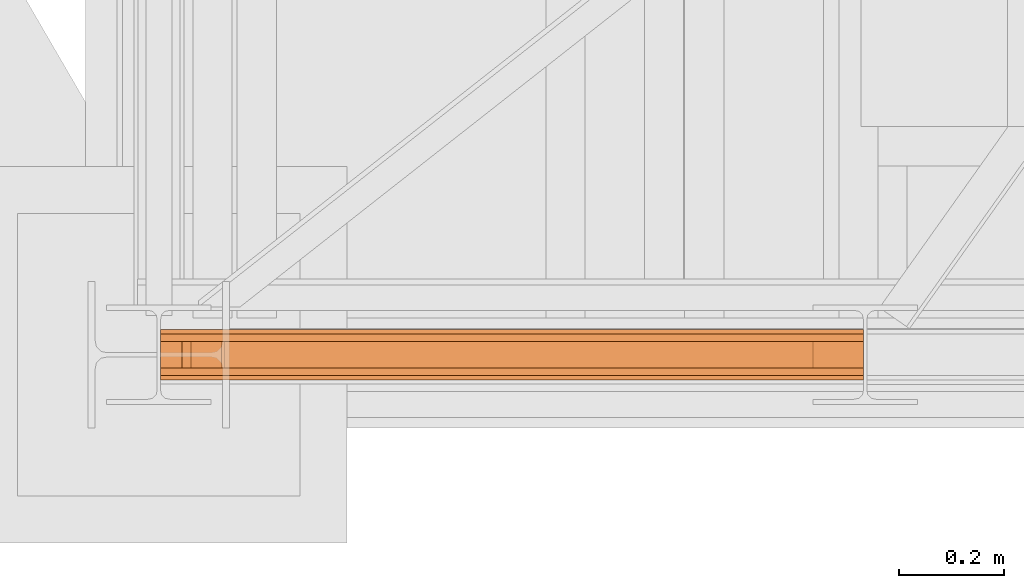
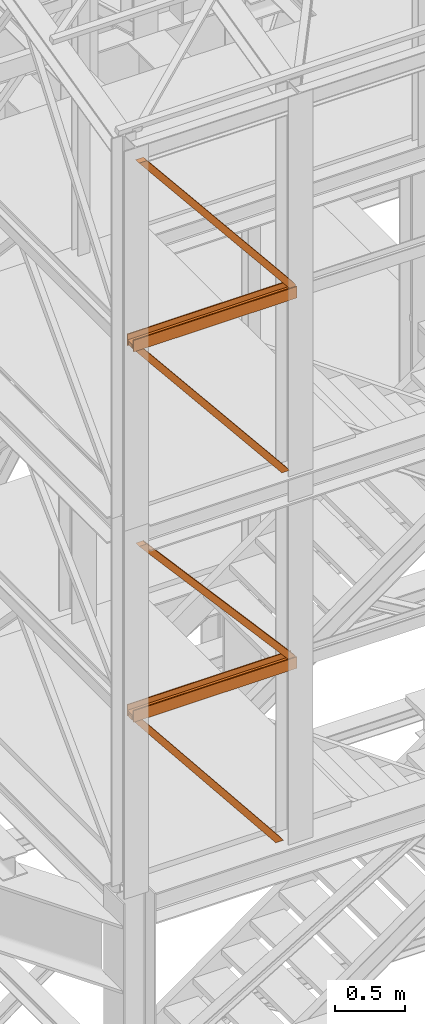
# One storey, part 6 of 208: 9 proxies.
"""IFC2X3 building model written with IfcOpenShell, lengths in millimetres."""

from ifc_helpers import new_model, entity, si_unit, converted_unit, frame, origin, origin_with_axes, place, context, subcontext, project, spatial, faceted_brep, element, save


model = new_model("IFC2X3")

# Units and contexts
model_context = context("Model", 3, precision=1e-05, world=origin())
plan_context = context("Plan", 3, precision=1e-05, world=origin())
body_context = subcontext(model_context, "Body", "Model", "MODEL_VIEW")
ifc_project = project(units=[si_unit("LENGTHUNIT", "METRE", prefix="MILLI"), converted_unit("PLANEANGLEUNIT", "DEGREE", entity("IfcPlaneAngleMeasure", 0.0174532925199433), si_unit("PLANEANGLEUNIT", "RADIAN"), dimensions=[0, 0, 0, 0, 0, 0, 0]), si_unit("AREAUNIT", "SQUARE_METRE"), si_unit("VOLUMEUNIT", "CUBIC_METRE")], contexts=[model_context, plan_context])

# Building, storey
building_placement = place(None, origin())
building = spatial("IfcBuilding", under=ifc_project, at=building_placement, CompositionType="COMPLEX")
storey_placement = place(building_placement, origin_with_axes())
storey = spatial("IfcBuildingStorey", under=building, at=storey_placement, Name="Geschoss", CompositionType="ELEMENT")

# Proxies
proxy_1_placement = place(storey_placement, frame((1201.504968595713, -25220.57439031787, 9979.990000745052), z_axis=(0.0, 0.0, 1.0), x_axis=(1.0, 0.0, 0.0)))
element("IfcBuildingElementProxy", 1, at=proxy_1_placement, inside=storey, context=body_context, shape_type="Brep", body=[
    faceted_brep([(0.009999999999990905, 8.0099999999984, 0.01000000000021828), (0.009999999999990905, 8.0099999999984, 47.51000000000022), (0.009999999999990905, 88.0099999999984, 47.51000000000022), (0.009999999999990905, 88.0099999999984, 0.01000000000021828), (0.009999999999990905, 96.0099999999984, 0.01000000000021828), (0.009999999999990905, 96.0099999999984, 100.0100000000002), (0.009999999999990905, 88.0099999999984, 100.0100000000002), (0.009999999999990905, 88.0099999999984, 52.51000000000022), (0.009999999999990905, 8.0099999999984, 52.51000000000022), (0.009999999999990905, 8.0099999999984, 100.0100000000002), (0.009999999999990905, 0.00999999999839929, 100.0100000000002), (0.009999999999990905, 0.00999999999839929, 0.01000000000021828), (0.009999999999990905, 0.00999999999839929, 0.01000000000021828), (1343.509999865892, 0.00999999999839929, 0.01000000000021828), (1343.509999865892, 8.0099999999984, 0.01000000000021828), (0.009999999999990905, 8.0099999999984, 0.01000000000021828), (0.009999999999990905, 0.00999999999839929, 100.0100000000002), (1343.509999865892, 0.00999999999839929, 100.0100000000002), (1343.509999865892, 0.00999999999839929, 0.01000000000021828), (0.009999999999990905, 0.00999999999839929, 0.01000000000021828), (0.009999999999990905, 8.0099999999984, 100.0100000000002), (1343.509999865892, 8.0099999999984, 100.0100000000002), (1343.509999865892, 0.00999999999839929, 100.0100000000002), (0.009999999999990905, 0.00999999999839929, 100.0100000000002), (0.009999999999990905, 8.0099999999984, 52.51000000000022), (1343.509999865892, 8.0099999999984, 52.51000000000022), (1343.509999865892, 8.0099999999984, 100.0100000000002), (0.009999999999990905, 8.0099999999984, 100.0100000000002), (0.009999999999990905, 88.0099999999984, 52.51000000000022), (1343.509999865892, 88.0099999999984, 52.51000000000022), (1343.509999865892, 8.0099999999984, 52.51000000000022), (0.009999999999990905, 8.0099999999984, 52.51000000000022), (0.009999999999990905, 88.0099999999984, 100.0100000000002), (1343.509999865892, 88.0099999999984, 100.0100000000002), (1343.509999865892, 88.0099999999984, 52.51000000000022), (0.009999999999990905, 88.0099999999984, 52.51000000000022), (0.009999999999990905, 96.0099999999984, 100.0100000000002), (1343.509999865892, 96.0099999999984, 100.0100000000002), (1343.509999865892, 88.0099999999984, 100.0100000000002), (0.009999999999990905, 88.0099999999984, 100.0100000000002), (0.009999999999990905, 96.0099999999984, 0.01000000000021828), (1343.509999865892, 96.0099999999984, 0.01000000000021828), (1343.509999865892, 96.0099999999984, 100.0100000000002), (0.009999999999990905, 96.0099999999984, 100.0100000000002), (0.009999999999990905, 88.0099999999984, 0.01000000000021828), (1343.509999865892, 88.0099999999984, 0.01000000000021828), (1343.509999865892, 96.0099999999984, 0.01000000000021828), (0.009999999999990905, 96.0099999999984, 0.01000000000021828), (0.009999999999990905, 88.0099999999984, 47.51000000000022), (1343.509999865892, 88.0099999999984, 47.51000000000022), (1343.509999865892, 88.0099999999984, 0.01000000000021828), (0.009999999999990905, 88.0099999999984, 0.01000000000021828), (0.009999999999990905, 8.0099999999984, 47.51000000000022), (1343.509999865892, 8.0099999999984, 47.51000000000022), (1343.509999865892, 88.0099999999984, 47.51000000000022), (0.009999999999990905, 88.0099999999984, 47.51000000000022), (0.009999999999990905, 8.0099999999984, 0.01000000000021828), (1343.509999865892, 8.0099999999984, 0.01000000000021828), (1343.509999865892, 8.0099999999984, 47.51000000000022), (0.009999999999990905, 8.0099999999984, 47.51000000000022), (1343.509999865892, 8.0099999999984, 0.01000000000021828), (1343.509999865892, 0.00999999999839929, 0.01000000000021828), (1343.509999865892, 0.00999999999839929, 100.0100000000002), (1343.509999865892, 8.0099999999984, 100.0100000000002), (1343.509999865892, 8.0099999999984, 52.51000000000022), (1343.509999865892, 88.0099999999984, 52.51000000000022), (1343.509999865892, 88.0099999999984, 100.0100000000002), (1343.509999865892, 96.0099999999984, 100.0100000000002), (1343.509999865892, 96.0099999999984, 0.01000000000021828), (1343.509999865892, 88.0099999999984, 0.01000000000021828), (1343.509999865892, 88.0099999999984, 47.51000000000022), (1343.509999865892, 8.0099999999984, 47.51000000000022)], [[[0, 1, 2, 3, 4, 5, 6, 7, 8, 9, 10, 11]], [[12, 13, 14, 15]], [[16, 17, 18, 19]], [[20, 21, 22, 23]], [[24, 25, 26, 27]], [[28, 29, 30, 31]], [[32, 33, 34, 35]], [[36, 37, 38, 39]], [[40, 41, 42, 43]], [[44, 45, 46, 47]], [[48, 49, 50, 51]], [[52, 53, 54, 55]], [[56, 57, 58, 59]], [[60, 61, 62, 63, 64, 65, 66, 67, 68, 69, 70, 71]]], orient=[[False], [False], [False], [False], [False], [False], [False], [False], [False], [False], [False], [False], [False], [False]]),
])
proxy_2_placement = place(storey_placement, frame((1201.504968595718, -25197.57439069041, 8483.504921504114), z_axis=(0.0, 0.0, 1.0), x_axis=(1.0, 0.0, 0.0)))
element("IfcBuildingElementProxy", 2, at=proxy_2_placement, inside=storey, context=body_context, shape_type="Brep", body=[
    faceted_brep([(1296.426322864608, 50.01000074505646, 0.01000000000021828), (1296.426322864607, 0.00999999999839929, 0.01000000000021828), (40.77580661443676, 0.00999999999839929, 1543.995079240938), (40.77580661443676, 50.01000074505646, 1543.995079240938), (1231.979047687171, 50.01000074505646, 0.01000000000021828), (1296.426322864608, 50.01000074505646, 0.01000000000021828), (40.77580661443676, 50.01000074505646, 1543.995079240938), (0.0100000000009004, 50.01000074505646, 1543.995079240938), (0.0100000000009004, 50.01000074505646, 1514.87564382273), (1231.979047687171, 0.00999999999839929, 0.01000000000021828), (1231.979047687171, 50.01000074505646, 0.01000000000021828), (0.0100000000009004, 50.01000074505646, 1514.87564382273), (0.009999999999990905, 0.00999999999839929, 1514.875643822732), (1296.426322864607, 0.00999999999839929, 0.01000000000021828), (1231.979047687171, 0.00999999999839929, 0.01000000000021828), (0.009999999999990905, 0.00999999999839929, 1514.875643822732), (0.009999999999990905, 0.00999999999839929, 1543.995079240938), (40.77580661443676, 0.00999999999839929, 1543.995079240938), (40.77580661443676, 0.00999999999839929, 1543.995079240938), (0.009999999999990905, 0.00999999999839929, 1543.995079240938), (0.0100000000009004, 50.01000074505646, 1543.995079240938), (40.77580661443676, 50.01000074505646, 1543.995079240938), (0.0100000000009004, 50.01000074505646, 1543.995079240938), (0.009999999999990905, 0.00999999999839929, 1543.995079240938), (0.009999999999990905, 0.00999999999839929, 1514.875643822732), (0.0100000000009004, 50.01000074505646, 1514.87564382273), (1296.426322864608, 50.01000074505646, 0.01000000000021828), (1231.979047687171, 50.01000074505646, 0.01000000000021828), (1231.979047687171, 0.00999999999839929, 0.01000000000021828), (1296.426322864607, 0.00999999999839929, 0.01000000000021828)], [[[0, 1, 2, 3]], [[4, 5, 6, 7, 8]], [[9, 10, 11, 12]], [[13, 14, 15, 16, 17]], [[18, 19, 20, 21]], [[22, 23, 24, 25]], [[26, 27, 28, 29]]], orient=[[False], [False], [False], [False], [False], [False], [False]]),
])
proxy_3_placement = place(storey_placement, frame((1259.555429022064, -25197.57439069041, 10044.49000051408), z_axis=(0.0, 0.0, 1.0), x_axis=(1.0, 0.0, 0.0)))
element("IfcBuildingElementProxy", 3, at=proxy_3_placement, inside=storey, context=body_context, shape_type="Brep", body=[
    faceted_brep([(1285.459539439543, 0.00999999999839929, 41.12943667735271), (64.49331271793176, 0.00999999999839929, 1542.465685831323), (64.49331271793176, 50.01000074505646, 1542.465685831323), (1285.459539439544, 50.01000074505646, 41.12943667735271), (1285.459539439544, 50.01000074505646, 41.12943667735271), (64.49331271793176, 50.01000074505646, 1542.465685831323), (58.7095442749694, 50.01000074505646, 1542.509998658894), (0.009999999999990905, 50.01000074505646, 1542.509998658894), (1254.452769993689, 50.01000074505646, 0.01000000000021828), (1285.459539439544, 50.01000074505646, 0.01000000000021828), (1254.452769993689, 50.01000074505646, 0.01000000000021828), (0.009999999999990905, 50.01000074505646, 1542.509998658894), (0.009999999999990905, 0.00999999999839929, 1542.509998658894), (1254.452769993689, 0.00999999999839929, 0.01000000000021828), (1285.459539439544, 0.00999999999839929, 0.01000000000021828), (1254.452769993689, 0.00999999999839929, 0.01000000000021828), (0.009999999999990905, 0.00999999999839929, 1542.509998658894), (58.7095442749694, 0.00999999999839929, 1542.509998658894), (64.49331271793176, 0.00999999999839929, 1542.465685831323), (1285.459539439543, 0.00999999999839929, 41.12943667735271), (58.7095442749694, 0.00999999999839929, 1542.509998658894), (0.009999999999990905, 0.00999999999839929, 1542.509998658894), (0.009999999999990905, 50.01000074505646, 1542.509998658894), (58.7095442749694, 50.01000074505646, 1542.509998658894), (58.7095442749694, 50.01000074505646, 1542.509998658894), (64.49331271793176, 50.01000074505646, 1542.465685831323), (64.49331271793176, 0.00999999999839929, 1542.465685831323), (58.7095442749694, 0.00999999999839929, 1542.509998658894), (1285.459539439544, 50.01000074505646, 0.01000000000021828), (1254.452769993689, 50.01000074505646, 0.01000000000021828), (1254.452769993689, 0.00999999999839929, 0.01000000000021828), (1285.459539439544, 0.00999999999839929, 0.01000000000021828), (1285.459539439544, 50.01000074505646, 41.12943667735271), (1285.459539439544, 50.01000074505646, 0.01000000000021828), (1285.459539439544, 0.00999999999839929, 0.01000000000021828), (1285.459539439543, 0.00999999999839929, 41.12943667735271)], [[[0, 1, 2, 3]], [[4, 5, 6, 7, 8, 9]], [[10, 11, 12, 13]], [[14, 15, 16, 17, 18, 19]], [[20, 21, 22, 23]], [[24, 25, 26, 27]], [[28, 29, 30, 31]], [[32, 33, 34, 35]]], orient=[[False], [False], [False], [False], [False], [False], [False], [False]]),
])
proxy_4_placement = place(storey_placement, frame((1201.504968595713, -25220.57439031787, 9979.990000745052), z_axis=(0.0, 0.0, 1.0), x_axis=(1.0, 0.0, 0.0)))
element("IfcBuildingElementProxy", 4, at=proxy_4_placement, inside=storey, context=body_context, shape_type="Brep", body=[
    faceted_brep([(0.009999999999990905, 8.0099999999984, 0.01000000000021828), (0.009999999999990905, 8.0099999999984, 47.51000000000022), (0.009999999999990905, 88.0099999999984, 47.51000000000022), (0.009999999999990905, 88.0099999999984, 0.01000000000021828), (0.009999999999990905, 96.0099999999984, 0.01000000000021828), (0.009999999999990905, 96.0099999999984, 100.0100000000002), (0.009999999999990905, 88.0099999999984, 100.0100000000002), (0.009999999999990905, 88.0099999999984, 52.51000000000022), (0.009999999999990905, 8.0099999999984, 52.51000000000022), (0.009999999999990905, 8.0099999999984, 100.0100000000002), (0.009999999999990905, 0.00999999999839929, 100.0100000000002), (0.009999999999990905, 0.00999999999839929, 0.01000000000021828), (0.009999999999990905, 0.00999999999839929, 0.01000000000021828), (1343.509999865892, 0.00999999999839929, 0.01000000000021828), (1343.509999865892, 8.0099999999984, 0.01000000000021828), (0.009999999999990905, 8.0099999999984, 0.01000000000021828), (0.009999999999990905, 0.00999999999839929, 100.0100000000002), (1343.509999865892, 0.00999999999839929, 100.0100000000002), (1343.509999865892, 0.00999999999839929, 0.01000000000021828), (0.009999999999990905, 0.00999999999839929, 0.01000000000021828), (0.009999999999990905, 8.0099999999984, 100.0100000000002), (1343.509999865892, 8.0099999999984, 100.0100000000002), (1343.509999865892, 0.00999999999839929, 100.0100000000002), (0.009999999999990905, 0.00999999999839929, 100.0100000000002), (0.009999999999990905, 8.0099999999984, 52.51000000000022), (1343.509999865892, 8.0099999999984, 52.51000000000022), (1343.509999865892, 8.0099999999984, 100.0100000000002), (0.009999999999990905, 8.0099999999984, 100.0100000000002), (0.009999999999990905, 88.0099999999984, 52.51000000000022), (1343.509999865892, 88.0099999999984, 52.51000000000022), (1343.509999865892, 8.0099999999984, 52.51000000000022), (0.009999999999990905, 8.0099999999984, 52.51000000000022), (0.009999999999990905, 88.0099999999984, 100.0100000000002), (1343.509999865892, 88.0099999999984, 100.0100000000002), (1343.509999865892, 88.0099999999984, 52.51000000000022), (0.009999999999990905, 88.0099999999984, 52.51000000000022), (0.009999999999990905, 96.0099999999984, 100.0100000000002), (1343.509999865892, 96.0099999999984, 100.0100000000002), (1343.509999865892, 88.0099999999984, 100.0100000000002), (0.009999999999990905, 88.0099999999984, 100.0100000000002), (0.009999999999990905, 96.0099999999984, 0.01000000000021828), (1343.509999865892, 96.0099999999984, 0.01000000000021828), (1343.509999865892, 96.0099999999984, 100.0100000000002), (0.009999999999990905, 96.0099999999984, 100.0100000000002), (0.009999999999990905, 88.0099999999984, 0.01000000000021828), (1343.509999865892, 88.0099999999984, 0.01000000000021828), (1343.509999865892, 96.0099999999984, 0.01000000000021828), (0.009999999999990905, 96.0099999999984, 0.01000000000021828), (0.009999999999990905, 88.0099999999984, 47.51000000000022), (1343.509999865892, 88.0099999999984, 47.51000000000022), (1343.509999865892, 88.0099999999984, 0.01000000000021828), (0.009999999999990905, 88.0099999999984, 0.01000000000021828), (0.009999999999990905, 8.0099999999984, 47.51000000000022), (1343.509999865892, 8.0099999999984, 47.51000000000022), (1343.509999865892, 88.0099999999984, 47.51000000000022), (0.009999999999990905, 88.0099999999984, 47.51000000000022), (0.009999999999990905, 8.0099999999984, 0.01000000000021828), (1343.509999865892, 8.0099999999984, 0.01000000000021828), (1343.509999865892, 8.0099999999984, 47.51000000000022), (0.009999999999990905, 8.0099999999984, 47.51000000000022), (1343.509999865892, 8.0099999999984, 0.01000000000021828), (1343.509999865892, 0.00999999999839929, 0.01000000000021828), (1343.509999865892, 0.00999999999839929, 100.0100000000002), (1343.509999865892, 8.0099999999984, 100.0100000000002), (1343.509999865892, 8.0099999999984, 52.51000000000022), (1343.509999865892, 88.0099999999984, 52.51000000000022), (1343.509999865892, 88.0099999999984, 100.0100000000002), (1343.509999865892, 96.0099999999984, 100.0100000000002), (1343.509999865892, 96.0099999999984, 0.01000000000021828), (1343.509999865892, 88.0099999999984, 0.01000000000021828), (1343.509999865892, 88.0099999999984, 47.51000000000022), (1343.509999865892, 8.0099999999984, 47.51000000000022)], [[[0, 1, 2, 3, 4, 5, 6, 7, 8, 9, 10, 11]], [[12, 13, 14, 15]], [[16, 17, 18, 19]], [[20, 21, 22, 23]], [[24, 25, 26, 27]], [[28, 29, 30, 31]], [[32, 33, 34, 35]], [[36, 37, 38, 39]], [[40, 41, 42, 43]], [[44, 45, 46, 47]], [[48, 49, 50, 51]], [[52, 53, 54, 55]], [[56, 57, 58, 59]], [[60, 61, 62, 63, 64, 65, 66, 67, 68, 69, 70, 71]]], orient=[[False], [False], [False], [False], [False], [False], [False], [False], [False], [False], [False], [False], [False], [False]]),
])
proxy_5_placement = place(storey_placement, frame((1201.504968595718, -25197.57439069041, 8483.504921504114), z_axis=(0.0, 0.0, 1.0), x_axis=(1.0, 0.0, 0.0)))
element("IfcBuildingElementProxy", 5, at=proxy_5_placement, inside=storey, context=body_context, shape_type="Brep", body=[
    faceted_brep([(1296.426322864608, 50.01000074505646, 0.01000000000021828), (1296.426322864607, 0.00999999999839929, 0.01000000000021828), (40.77580661443676, 0.00999999999839929, 1543.995079240938), (40.77580661443676, 50.01000074505646, 1543.995079240938), (1231.979047687171, 50.01000074505646, 0.01000000000021828), (1296.426322864608, 50.01000074505646, 0.01000000000021828), (40.77580661443676, 50.01000074505646, 1543.995079240938), (0.0100000000009004, 50.01000074505646, 1543.995079240938), (0.0100000000009004, 50.01000074505646, 1514.87564382273), (1231.979047687171, 0.00999999999839929, 0.01000000000021828), (1231.979047687171, 50.01000074505646, 0.01000000000021828), (0.0100000000009004, 50.01000074505646, 1514.87564382273), (0.009999999999990905, 0.00999999999839929, 1514.875643822732), (1296.426322864607, 0.00999999999839929, 0.01000000000021828), (1231.979047687171, 0.00999999999839929, 0.01000000000021828), (0.009999999999990905, 0.00999999999839929, 1514.875643822732), (0.009999999999990905, 0.00999999999839929, 1543.995079240938), (40.77580661443676, 0.00999999999839929, 1543.995079240938), (40.77580661443676, 0.00999999999839929, 1543.995079240938), (0.009999999999990905, 0.00999999999839929, 1543.995079240938), (0.0100000000009004, 50.01000074505646, 1543.995079240938), (40.77580661443676, 50.01000074505646, 1543.995079240938), (0.0100000000009004, 50.01000074505646, 1543.995079240938), (0.009999999999990905, 0.00999999999839929, 1543.995079240938), (0.009999999999990905, 0.00999999999839929, 1514.875643822732), (0.0100000000009004, 50.01000074505646, 1514.87564382273), (1296.426322864608, 50.01000074505646, 0.01000000000021828), (1231.979047687171, 50.01000074505646, 0.01000000000021828), (1231.979047687171, 0.00999999999839929, 0.01000000000021828), (1296.426322864607, 0.00999999999839929, 0.01000000000021828)], [[[0, 1, 2, 3]], [[4, 5, 6, 7, 8]], [[9, 10, 11, 12]], [[13, 14, 15, 16, 17]], [[18, 19, 20, 21]], [[22, 23, 24, 25]], [[26, 27, 28, 29]]], orient=[[False], [False], [False], [False], [False], [False], [False]]),
])
proxy_6_placement = place(storey_placement, frame((1259.555429022064, -25197.57439069041, 10044.49000051408), z_axis=(0.0, 0.0, 1.0), x_axis=(1.0, 0.0, 0.0)))
element("IfcBuildingElementProxy", 6, at=proxy_6_placement, inside=storey, context=body_context, shape_type="Brep", body=[
    faceted_brep([(1285.459539439543, 0.00999999999839929, 41.12943667735271), (64.49331271793176, 0.00999999999839929, 1542.465685831323), (64.49331271793176, 50.01000074505646, 1542.465685831323), (1285.459539439544, 50.01000074505646, 41.12943667735271), (1285.459539439544, 50.01000074505646, 41.12943667735271), (64.49331271793176, 50.01000074505646, 1542.465685831323), (58.7095442749694, 50.01000074505646, 1542.509998658894), (0.009999999999990905, 50.01000074505646, 1542.509998658894), (1254.452769993689, 50.01000074505646, 0.01000000000021828), (1285.459539439544, 50.01000074505646, 0.01000000000021828), (1254.452769993689, 50.01000074505646, 0.01000000000021828), (0.009999999999990905, 50.01000074505646, 1542.509998658894), (0.009999999999990905, 0.00999999999839929, 1542.509998658894), (1254.452769993689, 0.00999999999839929, 0.01000000000021828), (1285.459539439544, 0.00999999999839929, 0.01000000000021828), (1254.452769993689, 0.00999999999839929, 0.01000000000021828), (0.009999999999990905, 0.00999999999839929, 1542.509998658894), (58.7095442749694, 0.00999999999839929, 1542.509998658894), (64.49331271793176, 0.00999999999839929, 1542.465685831323), (1285.459539439543, 0.00999999999839929, 41.12943667735271), (58.7095442749694, 0.00999999999839929, 1542.509998658894), (0.009999999999990905, 0.00999999999839929, 1542.509998658894), (0.009999999999990905, 50.01000074505646, 1542.509998658894), (58.7095442749694, 50.01000074505646, 1542.509998658894), (58.7095442749694, 50.01000074505646, 1542.509998658894), (64.49331271793176, 50.01000074505646, 1542.465685831323), (64.49331271793176, 0.00999999999839929, 1542.465685831323), (58.7095442749694, 0.00999999999839929, 1542.509998658894), (1285.459539439544, 50.01000074505646, 0.01000000000021828), (1254.452769993689, 50.01000074505646, 0.01000000000021828), (1254.452769993689, 0.00999999999839929, 0.01000000000021828), (1285.459539439544, 0.00999999999839929, 0.01000000000021828), (1285.459539439544, 50.01000074505646, 41.12943667735271), (1285.459539439544, 50.01000074505646, 0.01000000000021828), (1285.459539439544, 0.00999999999839929, 0.01000000000021828), (1285.459539439543, 0.00999999999839929, 41.12943667735271)], [[[0, 1, 2, 3]], [[4, 5, 6, 7, 8, 9]], [[10, 11, 12, 13]], [[14, 15, 16, 17, 18, 19]], [[20, 21, 22, 23]], [[24, 25, 26, 27]], [[28, 29, 30, 31]], [[32, 33, 34, 35]]], orient=[[False], [False], [False], [False], [False], [False], [False], [False]]),
])
proxy_7_placement = place(storey_placement, frame((1201.504968595722, -25220.57438993343, 6759.989999254943), z_axis=(0.0, 0.0, 1.0), x_axis=(1.0, 0.0, 0.0)))
element("IfcBuildingElementProxy", 7, at=proxy_7_placement, inside=storey, context=body_context, shape_type="Brep", body=[
    faceted_brep([(0.009999999999990905, 88.0099999999984, 0.01000000000021828), (0.009999999999990905, 96.0099999999984, 0.01000000000021828), (0.009999999999990905, 96.0099999999984, 100.0100000000002), (0.009999999999990905, 88.0099999999984, 100.0100000000002), (0.009999999999990905, 88.0099999999984, 52.51000000000022), (0.009999999999990905, 8.0099999999984, 52.51000000000022), (0.009999999999990905, 8.0099999999984, 100.0100000000002), (0.009999999999990905, 0.00999999999839929, 100.0100000000002), (0.009999999999990905, 0.00999999999839929, 0.01000000000021828), (0.009999999999990905, 8.0099999999984, 0.01000000000021828), (0.009999999999990905, 8.0099999999984, 47.51000000000022), (0.009999999999990905, 88.0099999999984, 47.51000000000022), (0.009999999999990905, 96.0099999999984, 0.01000000000021828), (0.009999999999990905, 88.0099999999984, 0.01000000000021828), (1343.509999865888, 88.0099999999984, 0.01000000000021828), (1343.509999865888, 96.0099999999984, 0.01000000000021828), (0.009999999999990905, 96.0099999999984, 100.0100000000002), (0.009999999999990905, 96.0099999999984, 0.01000000000021828), (1343.509999865888, 96.0099999999984, 0.01000000000021828), (1343.509999865888, 96.0099999999984, 100.0100000000002), (0.009999999999990905, 88.0099999999984, 100.0100000000002), (0.009999999999990905, 96.0099999999984, 100.0100000000002), (1343.509999865888, 96.0099999999984, 100.0100000000002), (1343.509999865888, 88.0099999999984, 100.0100000000002), (0.009999999999990905, 88.0099999999984, 52.51000000000022), (0.009999999999990905, 88.0099999999984, 100.0100000000002), (1343.509999865888, 88.0099999999984, 100.0100000000002), (1343.509999865888, 88.0099999999984, 52.51000000000022), (0.009999999999990905, 8.0099999999984, 52.51000000000022), (0.009999999999990905, 88.0099999999984, 52.51000000000022), (1343.509999865888, 88.0099999999984, 52.51000000000022), (1343.509999865888, 8.0099999999984, 52.51000000000022), (0.009999999999990905, 8.0099999999984, 100.0100000000002), (0.009999999999990905, 8.0099999999984, 52.51000000000022), (1343.509999865888, 8.0099999999984, 52.51000000000022), (1343.509999865888, 8.0099999999984, 100.0100000000002), (0.009999999999990905, 0.00999999999839929, 100.0100000000002), (0.009999999999990905, 8.0099999999984, 100.0100000000002), (1343.509999865888, 8.0099999999984, 100.0100000000002), (1343.509999865888, 0.00999999999839929, 100.0100000000002), (0.009999999999990905, 0.00999999999839929, 0.01000000000021828), (0.009999999999990905, 0.00999999999839929, 100.0100000000002), (1343.509999865888, 0.00999999999839929, 100.0100000000002), (1343.509999865888, 0.00999999999839929, 0.01000000000021828), (0.009999999999990905, 8.0099999999984, 0.01000000000021828), (0.009999999999990905, 0.00999999999839929, 0.01000000000021828), (1343.509999865888, 0.00999999999839929, 0.01000000000021828), (1343.509999865888, 8.0099999999984, 0.01000000000021828), (0.009999999999990905, 8.0099999999984, 47.51000000000022), (0.009999999999990905, 8.0099999999984, 0.01000000000021828), (1343.509999865888, 8.0099999999984, 0.01000000000021828), (1343.509999865888, 8.0099999999984, 47.51000000000022), (0.009999999999990905, 88.0099999999984, 47.51000000000022), (0.009999999999990905, 8.0099999999984, 47.51000000000022), (1343.509999865888, 8.0099999999984, 47.51000000000022), (1343.509999865888, 88.0099999999984, 47.51000000000022), (0.009999999999990905, 88.0099999999984, 0.01000000000021828), (0.009999999999990905, 88.0099999999984, 47.51000000000022), (1343.509999865888, 88.0099999999984, 47.51000000000022), (1343.509999865888, 88.0099999999984, 0.01000000000021828), (1343.509999865888, 88.0099999999984, 0.01000000000021828), (1343.509999865888, 88.0099999999984, 47.51000000000022), (1343.509999865888, 8.0099999999984, 47.51000000000022), (1343.509999865888, 8.0099999999984, 0.01000000000021828), (1343.509999865888, 0.00999999999839929, 0.01000000000021828), (1343.509999865888, 0.00999999999839929, 100.0100000000002), (1343.509999865888, 8.0099999999984, 100.0100000000002), (1343.509999865888, 8.0099999999984, 52.51000000000022), (1343.509999865888, 88.0099999999984, 52.51000000000022), (1343.509999865888, 88.0099999999984, 100.0100000000002), (1343.509999865888, 96.0099999999984, 100.0100000000002), (1343.509999865888, 96.0099999999984, 0.01000000000021828)], [[[0, 1, 2, 3, 4, 5, 6, 7, 8, 9, 10, 11]], [[12, 13, 14, 15]], [[16, 17, 18, 19]], [[20, 21, 22, 23]], [[24, 25, 26, 27]], [[28, 29, 30, 31]], [[32, 33, 34, 35]], [[36, 37, 38, 39]], [[40, 41, 42, 43]], [[44, 45, 46, 47]], [[48, 49, 50, 51]], [[52, 53, 54, 55]], [[56, 57, 58, 59]], [[60, 61, 62, 63, 64, 65, 66, 67, 68, 69, 70, 71]]], orient=[[False], [False], [False], [False], [False], [False], [False], [False], [False], [False], [False], [False], [False], [False]]),
])
proxy_8_placement = place(storey_placement, frame((1201.50496859572, -25197.57439069041, 5284.990005364413), z_axis=(0.0, 0.0, 1.0), x_axis=(1.0, 0.0, 0.0)))
element("IfcBuildingElementProxy", 8, at=proxy_8_placement, inside=storey, context=body_context, shape_type="Brep", body=[
    faceted_brep([(1246.759998442829, 50.01000074505646, 0.01000000000112777), (1246.759998442828, 0.00999999999839929, 0.01000000000021828), (40.77580661443676, 0.00999999999839929, 1510.509994121497), (40.77580661443676, 50.01000074505646, 1510.509994121497), (1182.312723265392, 50.01000074505646, 0.01000000000112777), (1246.759998442829, 50.01000074505646, 0.01000000000112777), (40.77580661443676, 50.01000074505646, 1510.509994121497), (0.0100000000009004, 50.01000074505646, 1510.509994121497), (0.0100000000009004, 50.01000074505646, 1481.39055870329), (1182.312723265392, 0.00999999999839929, 0.01000000000112777), (1182.312723265392, 50.01000074505646, 0.01000000000112777), (0.0100000000009004, 50.01000074505646, 1481.39055870329), (0.009999999999990905, 0.00999999999839929, 1481.390558703291), (1246.759998442828, 0.00999999999839929, 0.01000000000021828), (1182.312723265392, 0.00999999999839929, 0.01000000000112777), (0.009999999999990905, 0.00999999999839929, 1481.390558703291), (0.009999999999990905, 0.00999999999839929, 1510.509994121498), (40.77580661443676, 0.00999999999839929, 1510.509994121497), (40.77580661443676, 0.00999999999839929, 1510.509994121497), (0.009999999999990905, 0.00999999999839929, 1510.509994121498), (0.0100000000009004, 50.01000074505646, 1510.509994121497), (40.77580661443676, 50.01000074505646, 1510.509994121497), (0.0100000000009004, 50.01000074505646, 1510.509994121497), (0.009999999999990905, 0.00999999999839929, 1510.509994121498), (0.009999999999990905, 0.00999999999839929, 1481.390558703291), (0.0100000000009004, 50.01000074505646, 1481.39055870329), (1246.759998442829, 50.01000074505646, 0.01000000000112777), (1182.312723265392, 50.01000074505646, 0.01000000000112777), (1182.312723265392, 0.00999999999839929, 0.01000000000112777), (1246.759998442828, 0.00999999999839929, 0.01000000000021828)], [[[0, 1, 2, 3]], [[4, 5, 6, 7, 8]], [[9, 10, 11, 12]], [[13, 14, 15, 16, 17]], [[18, 19, 20, 21]], [[22, 23, 24, 25]], [[26, 27, 28, 29]]], orient=[[False], [False], [False], [False], [False], [False], [False]]),
])
proxy_9_placement = place(storey_placement, frame((1259.555429022066, -25197.57439069041, 6812.489999254942), z_axis=(0.0, 0.0, 1.0), x_axis=(1.0, 0.0, 0.0)))
element("IfcBuildingElementProxy", 9, at=proxy_9_placement, inside=storey, context=body_context, shape_type="Brep", body=[
    faceted_brep([(1285.459539439543, 0.00999999999839929, 41.12943667735271), (58.70954427497031, 0.00999999999839929, 1449.577578879704), (58.70954427497031, 50.01000074505646, 1449.577578879704), (1285.459539439544, 50.01000074505646, 41.12943667735271), (1285.459539439544, 50.01000074505646, 41.12943667735271), (58.70954427497031, 50.01000074505646, 1449.577578879704), (58.7095442749694, 50.01000074505646, 1442.509998658894), (0.009999999999990905, 50.01000074505646, 1442.509998658894), (1254.452769993689, 50.01000074505646, 0.01000000000112777), (1285.459539439544, 50.01000074505646, 0.01000000000021828), (1254.452769993689, 50.01000074505646, 0.01000000000112777), (0.009999999999990905, 50.01000074505646, 1442.509998658894), (0.009999999999990905, 0.00999999999839929, 1442.509998658894), (1254.452769993689, 0.00999999999839929, 0.01000000000112777), (1285.459539439544, 0.00999999999839929, 0.01000000000021828), (1254.452769993689, 0.00999999999839929, 0.01000000000112777), (0.009999999999990905, 0.00999999999839929, 1442.509998658894), (58.7095442749694, 0.00999999999839929, 1442.509998658894), (58.70954427497031, 0.00999999999839929, 1449.577578879704), (1285.459539439543, 0.00999999999839929, 41.12943667735271), (58.7095442749694, 0.00999999999839929, 1442.509998658894), (0.009999999999990905, 0.00999999999839929, 1442.509998658894), (0.009999999999990905, 50.01000074505646, 1442.509998658894), (58.7095442749694, 50.01000074505646, 1442.509998658894), (58.7095442749694, 50.01000074505646, 1442.509998658894), (58.70954427497031, 50.01000074505646, 1449.577578879704), (58.70954427497031, 0.00999999999839929, 1449.577578879704), (58.7095442749694, 0.00999999999839929, 1442.509998658894), (1285.459539439544, 50.01000074505646, 0.01000000000021828), (1254.452769993689, 50.01000074505646, 0.01000000000112777), (1254.452769993689, 0.00999999999839929, 0.01000000000112777), (1285.459539439544, 0.00999999999839929, 0.01000000000021828), (1285.459539439544, 50.01000074505646, 41.12943667735271), (1285.459539439544, 50.01000074505646, 0.01000000000021828), (1285.459539439544, 0.00999999999839929, 0.01000000000021828), (1285.459539439543, 0.00999999999839929, 41.12943667735271)], [[[0, 1, 2, 3]], [[4, 5, 6, 7, 8, 9]], [[10, 11, 12, 13]], [[14, 15, 16, 17, 18, 19]], [[20, 21, 22, 23]], [[24, 25, 26, 27]], [[28, 29, 30, 31]], [[32, 33, 34, 35]]], orient=[[False], [False], [False], [False], [False], [False], [False], [False]]),
])

save(model, "model.ifc")
